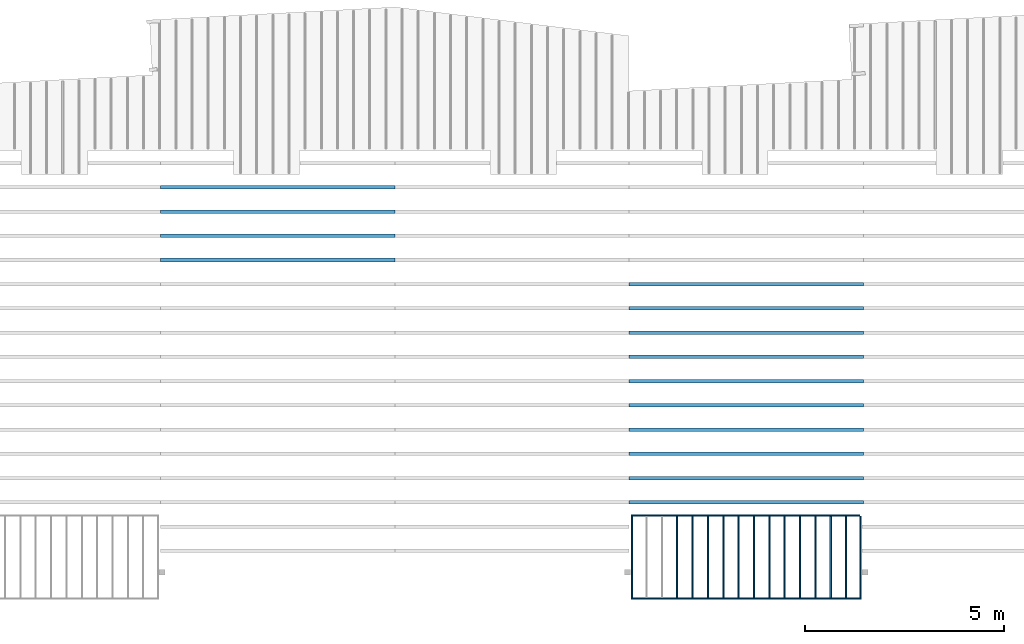
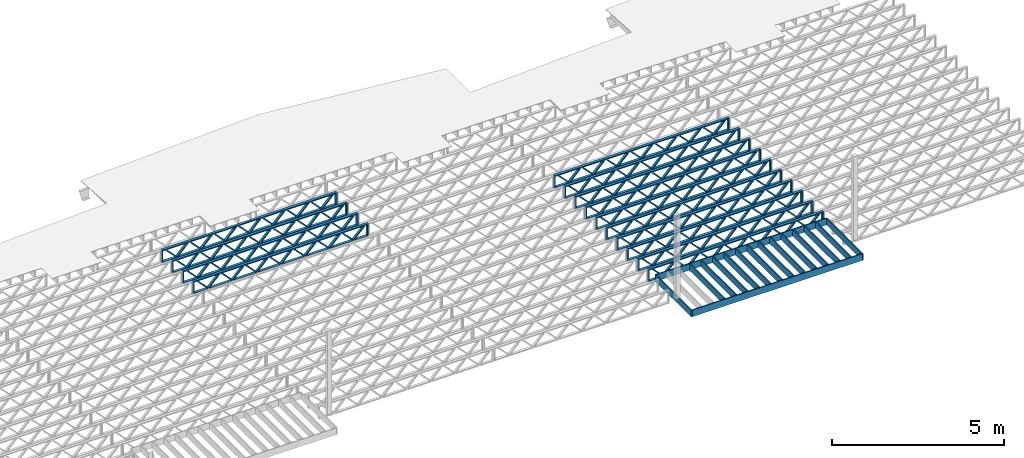
# One storey, part 7 of 13: 30 beams, 3 elements without a shape of their own.
"""IFC4 building model written with IfcOpenShell, lengths in feet."""

from ifc_helpers import new_model, entity, si_unit, converted_unit, derived_unit, direction, frame, frame_2d, origin, origin_2d_with_axis, place, context, subcontext, project, spatial, rectangle, extrude, source, transform, mapped, material, material_profile, profile_set, profile_usage, type_object, type_shapes, element, aggregate, save


model = new_model("IFC4")

# Units and contexts
model_context_1 = context("Model", 3, precision=0.0001, world=origin(), true_north=direction((6.12303176911189e-17, 1.0)))
model_context_2 = context("Model", 3, precision=0.0001, world=origin(), true_north=direction((6.12303176911189e-17, 1.0)))
body_context = subcontext(model_context_2, "Body", "Model", "MODEL_VIEW")
ifc_project = project(units=[converted_unit("LENGTHUNIT", "FOOT", entity("IfcRatioMeasure", 0.3048), si_unit("LENGTHUNIT", "METRE"), dimensions=[1, 0, 0, 0, 0, 0, 0]), converted_unit("AREAUNIT", "SQUARE FOOT", entity("IfcRatioMeasure", 0.09290304), si_unit("AREAUNIT", "SQUARE_METRE"), dimensions=[2, 0, 0, 0, 0, 0, 0]), converted_unit("VOLUMEUNIT", "CUBIC FOOT", entity("IfcRatioMeasure", 0.028316846592), si_unit("VOLUMEUNIT", "CUBIC_METRE"), dimensions=[3, 0, 0, 0, 0, 0, 0]), converted_unit("PLANEANGLEUNIT", "DEGREE", entity("IfcRatioMeasure", 0.0174532925199433), si_unit("PLANEANGLEUNIT", "RADIAN"), dimensions=[0, 0, 0, 0, 0, 0, 0]), si_unit("MASSUNIT", "GRAM", prefix="KILO"), derived_unit("MASSDENSITYUNIT", [(si_unit("MASSUNIT", "GRAM", prefix="KILO"), 1), (si_unit("LENGTHUNIT", "METRE"), -3)]), derived_unit("MOMENTOFINERTIAUNIT", [(si_unit("LENGTHUNIT", "METRE"), 4)]), si_unit("TIMEUNIT", "SECOND"), si_unit("FREQUENCYUNIT", "HERTZ"), si_unit("THERMODYNAMICTEMPERATUREUNIT", "DEGREE_CELSIUS"), derived_unit("THERMALTRANSMITTANCEUNIT", [(si_unit("MASSUNIT", "GRAM", prefix="KILO"), 1), (si_unit("THERMODYNAMICTEMPERATUREUNIT", "KELVIN"), -1), (si_unit("TIMEUNIT", "SECOND"), -3)]), derived_unit("VOLUMETRICFLOWRATEUNIT", [(si_unit("LENGTHUNIT", "METRE"), 3), (si_unit("TIMEUNIT", "SECOND"), -1)]), si_unit("ELECTRICCURRENTUNIT", "AMPERE"), si_unit("ELECTRICVOLTAGEUNIT", "VOLT"), si_unit("POWERUNIT", "WATT"), si_unit("FORCEUNIT", "NEWTON"), si_unit("ILLUMINANCEUNIT", "LUX"), si_unit("LUMINOUSFLUXUNIT", "LUMEN"), si_unit("LUMINOUSINTENSITYUNIT", "CANDELA"), derived_unit("USERDEFINED", [(si_unit("MASSUNIT", "GRAM", prefix="KILO"), -1), (si_unit("LENGTHUNIT", "METRE"), -2), (si_unit("TIMEUNIT", "SECOND"), 3), (si_unit("LUMINOUSFLUXUNIT", "LUMEN"), 1)]), derived_unit("LINEARVELOCITYUNIT", [(si_unit("LENGTHUNIT", "METRE"), 1), (si_unit("TIMEUNIT", "SECOND"), -1)]), si_unit("PRESSUREUNIT", "PASCAL"), derived_unit("USERDEFINED", [(si_unit("LENGTHUNIT", "METRE"), -2), (si_unit("MASSUNIT", "GRAM", prefix="KILO"), 1), (si_unit("TIMEUNIT", "SECOND"), -2)]), derived_unit("LINEARFORCEUNIT", [(si_unit("MASSUNIT", "GRAM", prefix="KILO"), 1), (si_unit("LENGTHUNIT", "METRE"), 1), (si_unit("TIMEUNIT", "SECOND"), -2), (si_unit("LENGTHUNIT", "METRE"), -1)]), derived_unit("PLANARFORCEUNIT", [(si_unit("MASSUNIT", "GRAM", prefix="KILO"), 1), (si_unit("LENGTHUNIT", "METRE"), 1), (si_unit("TIMEUNIT", "SECOND"), -2), (si_unit("LENGTHUNIT", "METRE"), -2)])], contexts=[model_context_1])

# Site, building, storey
site_placement = place(None, origin())
site = spatial("IfcSite", under=ifc_project, at=site_placement, CompositionType="ELEMENT")
building_placement = place(site_placement, origin())
building = spatial("IfcBuilding", under=site, at=building_placement, CompositionType="ELEMENT")
storey_placement = place(building_placement, frame((0.0, 0.0, 21.46875)))
storey = spatial("IfcBuildingStorey", under=building, at=storey_placement, Name="3RD FLOOR", CompositionType="ELEMENT", Elevation=21.46875)

# Assembly, beams
assembly_1_placement = place(storey_placement, origin())
assembly_1 = element("IfcElementAssembly", 1, at=assembly_1_placement, inside=storey, Name="Structural Beam System:Structural Framing System", ObjectType="Structural Beam System:Structural Framing System", AssemblyPlace="NOTDEFINED", PredefinedType="BEAM_GRID")
ifc_material_1 = material(Name="WOOD TRUSS", Category="Materials")
ifc_material_profile_1 = material_profile(ifc_material_1, rectangle(XDim=1.73473973950632, YDim=0.125, at=frame_2d((-1.11022302462516e-16, 8.32667268468867e-17), x_axis=(1.0, 0.0))))
ifc_material_profile_2 = material_profile(ifc_material_1, rectangle(XDim=1.73473973950633, YDim=0.125, at=frame_2d((-1.11022302462516e-16, 8.32667268468867e-17), x_axis=(1.0, 0.0))))
ifc_material_profile_3 = material_profile(ifc_material_1, rectangle(XDim=1.73473973950632, YDim=0.125, at=frame_2d((-5.55111512312578e-17, 1.38777878078145e-16), x_axis=(1.0, 0.0))))
ifc_material_profile_4 = material_profile(ifc_material_1, rectangle(XDim=1.73473973950633, YDim=0.125, at=frame_2d((-1.11022302462516e-16, 8.32667268468867e-17), x_axis=(1.0, 0.0))))
ifc_material_profile_5 = material_profile(ifc_material_1, rectangle(XDim=1.73473973950632, YDim=0.125, at=frame_2d((-1.11022302462516e-16, 8.32667268468867e-17), x_axis=(1.0, 0.0))))
ifc_material_profile_6 = material_profile(ifc_material_1, rectangle(XDim=1.73473973950633, YDim=0.125, at=frame_2d((-2.77555756156289e-16, 3.05311331771918e-16), x_axis=(1.0, 0.0))))
ifc_material_profile_7 = material_profile(ifc_material_1, rectangle(XDim=1.73473973950632, YDim=0.124999999999999, at=frame_2d((-3.88578058618805e-16, -2.4980018054066e-16), x_axis=(1.0, 0.0))))
ifc_material_profile_8 = material_profile(ifc_material_1, rectangle(XDim=1.73473973950633, YDim=0.125, at=frame_2d((2.77555756156289e-16, -3.05311331771918e-16), x_axis=(1.0, 0.0))))
ifc_material_profile_9 = material_profile(ifc_material_1, rectangle(XDim=1.73473973950632, YDim=0.124999999999999, at=frame_2d((-1.11022302462516e-16, 8.32667268468867e-17), x_axis=(1.0, 0.0))))
ifc_material_profile_10 = material_profile(ifc_material_1, rectangle(XDim=1.73473973950633, YDim=0.125, at=origin_2d_with_axis()))
ifc_material_profile_11 = material_profile(ifc_material_1, rectangle(XDim=0.124999999999982, YDim=0.291666666666668, at=origin_2d_with_axis()))
ifc_material_profile_12 = material_profile(ifc_material_1, rectangle(XDim=0.124999999999932, YDim=0.291666666666664, at=origin_2d_with_axis()))
ifc_material_profile_13 = material_profile(ifc_material_1, rectangle(XDim=1.25000000000002, YDim=0.29166666666667, at=origin_2d_with_axis()))
ifc_material_profile_14 = material_profile(ifc_material_1, rectangle(XDim=1.25000000000004, YDim=0.291666666666667, at=origin_2d_with_axis()))
ifc_profile_set_1 = profile_set([ifc_material_profile_1, ifc_material_profile_2, ifc_material_profile_3, ifc_material_profile_4, ifc_material_profile_5, ifc_material_profile_6, ifc_material_profile_7, ifc_material_profile_8, ifc_material_profile_9, ifc_material_profile_10, ifc_material_profile_11, ifc_material_profile_12, ifc_material_profile_13, ifc_material_profile_14])
ifc_profile_usage_1 = profile_usage(ifc_profile_set_1, cardinal=8)
beam_type_1 = type_object("IfcBeamType", PredefinedType="BEAM", material=ifc_profile_set_1)
shared_shape_1 = source(origin(), body_context, "Body", "SweptSolid", [
    extrude(rectangle(XDim=1.73473973950632, YDim=0.124999999999999, at=frame_2d((5.55111512312578e-16, 7.21644966006352e-16), x_axis=(1.0, 0.0))), frame((5.95847627016997, -0.145833333333334, 0.0), z_axis=(0.0, 1.0, 0.0), x_axis=(0.693383046997606, 0.0, 0.720569184836762)), (0.0, 0.0, 1.0), 0.291666666666667),
    extrude(rectangle(XDim=1.73473973950633, YDim=0.125, at=origin_2d_with_axis()), frame((4.7081903964967, -0.145833333333334, 0.0), z_axis=(0.0, 1.0, 0.0), x_axis=(0.69338304699761, 0.0, -0.720569184836758)), (0.0, 0.0, 1.0), 0.291666666666666),
    extrude(rectangle(XDim=1.73473973950632, YDim=0.125, at=frame_2d((2.22044604925031e-16, 3.88578058618805e-16), x_axis=(1.0, 0.0))), frame((3.29180960350347, -0.145833333333334, 0.0), z_axis=(0.0, 1.0, 0.0), x_axis=(0.693383046997606, 0.0, 0.720569184836762)), (0.0, 0.0, 1.0), 0.291666666666667),
    extrude(rectangle(XDim=1.73473973950633, YDim=0.125, at=frame_2d((1.11022302462516e-16, -8.32667268468867e-17), x_axis=(1.0, 0.0))), frame((2.0415237298302, -0.145833333333334, 0.0), z_axis=(0.0, 1.0, 0.0), x_axis=(0.69338304699761, 0.0, -0.720569184836758)), (0.0, 0.0, 1.0), 0.291666666666667),
    extrude(rectangle(XDim=1.73473973950632, YDim=0.125, at=frame_2d((-5.55111512312578e-17, 1.38777878078145e-16), x_axis=(1.0, 0.0))), frame((0.625142936836964, -0.145833333333334, 0.0), z_axis=(0.0, 1.0, 0.0), x_axis=(0.693383046997606, 0.0, 0.720569184836762)), (0.0, 0.0, 1.0), 0.291666666666667),
    extrude(rectangle(XDim=1.73473973950633, YDim=0.125, at=frame_2d((-1.11022302462516e-16, 8.32667268468867e-17), x_axis=(1.0, 0.0))), frame((-0.625142936836306, -0.145833333333334, 0.0), z_axis=(0.0, 1.0, 0.0), x_axis=(0.69338304699761, 0.0, -0.720569184836758)), (0.0, 0.0, 1.0), 0.291666666666667),
    extrude(rectangle(XDim=1.73473973950632, YDim=0.125, at=frame_2d((-1.11022302462516e-16, 8.32667268468867e-17), x_axis=(1.0, 0.0))), frame((-2.04152372982954, -0.145833333333334, 0.0), z_axis=(0.0, 1.0, 0.0), x_axis=(0.693383046997606, 0.0, 0.720569184836762)), (0.0, 0.0, 1.0), 0.291666666666667),
    extrude(rectangle(XDim=1.73473973950633, YDim=0.125, at=origin_2d_with_axis()), frame((-3.29180960350281, -0.145833333333334, 0.0), z_axis=(0.0, 1.0, 0.0), x_axis=(0.69338304699761, 0.0, -0.720569184836758)), (0.0, 0.0, 1.0), 0.291666666666667),
    extrude(rectangle(XDim=1.73473973950632, YDim=0.124999999999999, at=frame_2d((-1.11022302462516e-16, 8.32667268468867e-17), x_axis=(1.0, 0.0))), frame((-4.70819039649604, -0.145833333333334, 0.0), z_axis=(0.0, 1.0, 0.0), x_axis=(0.693383046997606, 0.0, 0.720569184836762)), (0.0, 0.0, 1.0), 0.291666666666667),
    extrude(rectangle(XDim=1.73473973950633, YDim=0.125, at=frame_2d((-5.55111512312578e-16, 6.38378239159465e-16), x_axis=(1.0, 0.0))), frame((-5.95847627016931, -0.145833333333334, 0.0), z_axis=(0.0, 1.0, 0.0), x_axis=(0.69338304699761, 0.0, -0.720569184836758)), (0.0, 0.0, 1.0), 0.291666666666666),
    extrude(rectangle(XDim=1.73473973950632, YDim=0.125, at=frame_2d((-7.21644966006352e-16, -5.82867087928207e-16), x_axis=(1.0, 0.0))), frame((8.62514293683647, -0.145833333333334, 0.0), z_axis=(0.0, 1.0, 0.0), x_axis=(0.693383046997607, 0.0, 0.720569184836761)), (0.0, 0.0, 1.0), 0.291666666666667),
    extrude(rectangle(XDim=1.73473973950633, YDim=0.125, at=origin_2d_with_axis()), frame((7.3748570631632, -0.145833333333334, 0.0), z_axis=(0.0, 1.0, 0.0), x_axis=(0.69338304699761, 0.0, -0.720569184836758)), (0.0, 0.0, 1.0), 0.291666666666666),
    extrude(rectangle(XDim=1.73473973950632, YDim=0.124999999999999, at=frame_2d((-1.11022302462516e-16, 8.32667268468867e-17), x_axis=(1.0, 0.0))), frame((-7.37485706316255, -0.145833333333334, 0.0), z_axis=(0.0, 1.0, 0.0), x_axis=(0.693383046997606, 0.0, 0.720569184836762)), (0.0, 0.0, 1.0), 0.291666666666667),
    extrude(rectangle(XDim=1.73473973950633, YDim=0.125, at=origin_2d_with_axis()), frame((-8.62514293683582, -0.145833333333334, 0.0), z_axis=(0.0, 1.0, 0.0), x_axis=(0.69338304699761, 0.0, -0.720569184836758)), (0.0, 0.0, 1.0), 0.291666666666666),
    extrude(rectangle(XDim=0.124999999999982, YDim=0.291666666666668, at=origin_2d_with_axis()), frame((-9.66666666666609, 0.0, 0.687500000000054), z_axis=(1.0, 0.0, 0.0), x_axis=(0.0, 0.0, -1.0)), (0.0, 0.0, 1.0), 19.3333333333322),
    extrude(rectangle(XDim=0.124999999999932, YDim=0.291666666666664, at=origin_2d_with_axis()), frame((-9.66666666666588, 0.0, -0.687499999999984), z_axis=(1.0, 0.0, 0.0), x_axis=(0.0, 0.0, -1.0)), (0.0, 0.0, 1.0), 19.333333333332),
    extrude(rectangle(XDim=1.25000000000002, YDim=0.29166666666667, at=origin_2d_with_axis()), frame((9.54166666666607, 0.0, 0.0), z_axis=(1.0, 0.0, 0.0), x_axis=(0.0, 0.0, -1.0)), (0.0, 0.0, 1.0), 0.12500000000002),
    extrude(rectangle(XDim=1.25000000000004, YDim=0.291666666666667, at=origin_2d_with_axis()), frame((-9.66666666666609, 0.0, 0.0), z_axis=(1.0, 0.0, 0.0), x_axis=(0.0, 0.0, -1.0)), (0.0, 0.0, 1.0), 0.125000000000023),
])
type_shapes(beam_type_1, [shared_shape_1])
beam_1_placement = place(assembly_1_placement, frame((-174.071493818896, 947.861934882651, -0.947916666666661), z_axis=(0.0, 0.0, 1.0), x_axis=(-1.0, 0.0, 0.0)))
beam_1 = element("IfcBeam", 2, at=beam_1_placement, type_object=beam_type_1, material=ifc_profile_usage_1, PredefinedType="BEAM", context=body_context, shape_type="MappedRepresentation", body=[
    mapped(shared_shape_1, transform((0.0, 0.0, 0.0), scale=1.0)),
])
ifc_profile_usage_2 = profile_usage(ifc_profile_set_1, cardinal=8)
beam_2_placement = place(assembly_1_placement, frame((-174.071493818896, 945.861934882651, -0.947916666666661), z_axis=(0.0, 0.0, 1.0), x_axis=(-1.0, 0.0, 0.0)))
beam_2 = element("IfcBeam", 3, at=beam_2_placement, type_object=beam_type_1, material=ifc_profile_usage_2, PredefinedType="BEAM", context=body_context, shape_type="MappedRepresentation", body=[
    mapped(shared_shape_1, transform((0.0, 0.0, 0.0), scale=1.0)),
])
ifc_profile_usage_3 = profile_usage(ifc_profile_set_1, cardinal=8)
beam_3_placement = place(assembly_1_placement, frame((-174.071493818896, 943.861934882651, -0.947916666666661), z_axis=(0.0, 0.0, 1.0), x_axis=(-1.0, 0.0, 0.0)))
beam_3 = element("IfcBeam", 4, at=beam_3_placement, type_object=beam_type_1, material=ifc_profile_usage_3, PredefinedType="BEAM", context=body_context, shape_type="MappedRepresentation", body=[
    mapped(shared_shape_1, transform((0.0, 0.0, 0.0), scale=1.0)),
])
ifc_profile_usage_4 = profile_usage(ifc_profile_set_1, cardinal=8)
beam_4_placement = place(assembly_1_placement, frame((-174.071493818896, 941.861934882651, -0.947916666666661), z_axis=(0.0, 0.0, 1.0), x_axis=(-1.0, 0.0, 0.0)))
beam_4 = element("IfcBeam", 5, at=beam_4_placement, type_object=beam_type_1, material=ifc_profile_usage_4, PredefinedType="BEAM", context=body_context, shape_type="MappedRepresentation", body=[
    mapped(shared_shape_1, transform((0.0, 0.0, 0.0), scale=1.0)),
])
ifc_profile_usage_5 = profile_usage(ifc_profile_set_1, cardinal=8)
beam_5_placement = place(assembly_1_placement, frame((-174.071493818896, 939.861934882651, -0.947916666666661), z_axis=(0.0, 0.0, 1.0), x_axis=(-1.0, 0.0, 0.0)))
beam_5 = element("IfcBeam", 6, at=beam_5_placement, type_object=beam_type_1, material=ifc_profile_usage_5, PredefinedType="BEAM", context=body_context, shape_type="MappedRepresentation", body=[
    mapped(shared_shape_1, transform((0.0, 0.0, 0.0), scale=1.0)),
])
ifc_profile_usage_6 = profile_usage(ifc_profile_set_1, cardinal=8)
beam_6_placement = place(assembly_1_placement, frame((-174.071493818896, 937.861934882651, -0.947916666666661), z_axis=(0.0, 0.0, 1.0), x_axis=(-1.0, 0.0, 0.0)))
beam_6 = element("IfcBeam", 7, at=beam_6_placement, type_object=beam_type_1, material=ifc_profile_usage_6, PredefinedType="BEAM", context=body_context, shape_type="MappedRepresentation", body=[
    mapped(shared_shape_1, transform((0.0, 0.0, 0.0), scale=1.0)),
])
ifc_profile_usage_7 = profile_usage(ifc_profile_set_1, cardinal=8)
beam_7_placement = place(assembly_1_placement, frame((-174.071493818896, 935.861934882651, -0.947916666666661), z_axis=(0.0, 0.0, 1.0), x_axis=(-1.0, 0.0, 0.0)))
beam_7 = element("IfcBeam", 8, at=beam_7_placement, type_object=beam_type_1, material=ifc_profile_usage_7, PredefinedType="BEAM", context=body_context, shape_type="MappedRepresentation", body=[
    mapped(shared_shape_1, transform((0.0, 0.0, 0.0), scale=1.0)),
])
ifc_profile_usage_8 = profile_usage(ifc_profile_set_1, cardinal=8)
beam_8_placement = place(assembly_1_placement, frame((-174.071493818896, 933.861934882651, -0.947916666666661), z_axis=(0.0, 0.0, 1.0), x_axis=(-1.0, 0.0, 0.0)))
beam_8 = element("IfcBeam", 9, at=beam_8_placement, type_object=beam_type_1, material=ifc_profile_usage_8, PredefinedType="BEAM", context=body_context, shape_type="MappedRepresentation", body=[
    mapped(shared_shape_1, transform((0.0, 0.0, 0.0), scale=1.0)),
])
ifc_profile_usage_9 = profile_usage(ifc_profile_set_1, cardinal=8)
beam_9_placement = place(assembly_1_placement, frame((-174.071493818896, 931.861934882651, -0.947916666666661), z_axis=(0.0, 0.0, 1.0), x_axis=(-1.0, 0.0, 0.0)))
beam_9 = element("IfcBeam", 10, at=beam_9_placement, type_object=beam_type_1, material=ifc_profile_usage_9, PredefinedType="BEAM", context=body_context, shape_type="MappedRepresentation", body=[
    mapped(shared_shape_1, transform((0.0, 0.0, 0.0), scale=1.0)),
])
ifc_profile_usage_10 = profile_usage(ifc_profile_set_1, cardinal=8)
beam_10_placement = place(assembly_1_placement, frame((-174.071493818896, 929.861934882651, -0.947916666666661), z_axis=(0.0, 0.0, 1.0), x_axis=(-1.0, 0.0, 0.0)))
beam_10 = element("IfcBeam", 11, at=beam_10_placement, type_object=beam_type_1, material=ifc_profile_usage_10, PredefinedType="BEAM", context=body_context, shape_type="MappedRepresentation", body=[
    mapped(shared_shape_1, transform((0.0, 0.0, 0.0), scale=1.0)),
])
aggregate(assembly_1, [beam_1, beam_2, beam_3, beam_4, beam_5, beam_6, beam_7, beam_8, beam_9, beam_10])

assembly_2_placement = place(storey_placement, origin())
assembly_2 = element("IfcElementAssembly", 12, at=assembly_2_placement, inside=storey, Name="Structural Beam System:Structural Framing System", ObjectType="Structural Beam System:Structural Framing System", AssemblyPlace="NOTDEFINED", PredefinedType="BEAM_GRID")
ifc_profile_usage_11 = profile_usage(ifc_profile_set_1, cardinal=8)
beam_11_placement = place(assembly_2_placement, frame((-212.738160485495, 955.861934882651, -0.947916666666881), z_axis=(0.0, 0.0, 1.0), x_axis=(-1.0, 0.0, 0.0)))
beam_11 = element("IfcBeam", 13, at=beam_11_placement, type_object=beam_type_1, material=ifc_profile_usage_11, PredefinedType="BEAM", context=body_context, shape_type="MappedRepresentation", body=[
    mapped(shared_shape_1, transform((0.0, 0.0, 0.0), scale=1.0)),
])
ifc_profile_usage_12 = profile_usage(ifc_profile_set_1, cardinal=8)
beam_12_placement = place(assembly_2_placement, frame((-212.738160485495, 953.861934882651, -0.947916666666881), z_axis=(0.0, 0.0, 1.0), x_axis=(-1.0, 0.0, 0.0)))
beam_12 = element("IfcBeam", 14, at=beam_12_placement, type_object=beam_type_1, material=ifc_profile_usage_12, PredefinedType="BEAM", context=body_context, shape_type="MappedRepresentation", body=[
    mapped(shared_shape_1, transform((0.0, 0.0, 0.0), scale=1.0)),
])
ifc_profile_usage_13 = profile_usage(ifc_profile_set_1, cardinal=8)
beam_13_placement = place(assembly_2_placement, frame((-212.738160485495, 951.861934882651, -0.947916666666881), z_axis=(0.0, 0.0, 1.0), x_axis=(-1.0, 0.0, 0.0)))
beam_13 = element("IfcBeam", 15, at=beam_13_placement, type_object=beam_type_1, material=ifc_profile_usage_13, PredefinedType="BEAM", context=body_context, shape_type="MappedRepresentation", body=[
    mapped(shared_shape_1, transform((0.0, 0.0, 0.0), scale=1.0)),
])
ifc_profile_usage_14 = profile_usage(ifc_profile_set_1, cardinal=8)
beam_14_placement = place(assembly_2_placement, frame((-212.738160485495, 949.861934882651, -0.947916666666881), z_axis=(0.0, 0.0, 1.0), x_axis=(-1.0, 0.0, 0.0)))
beam_14 = element("IfcBeam", 16, at=beam_14_placement, type_object=beam_type_1, material=ifc_profile_usage_14, PredefinedType="BEAM", context=body_context, shape_type="MappedRepresentation", body=[
    mapped(shared_shape_1, transform((0.0, 0.0, 0.0), scale=1.0)),
])
aggregate(assembly_2, [beam_11, beam_12, beam_13, beam_14])

assembly_3_placement = place(storey_placement, origin())
assembly_3 = element("IfcElementAssembly", 17, at=assembly_3_placement, inside=storey, Name="Structural Beam System:Structural Framing System", ObjectType="Structural Beam System:Structural Framing System", AssemblyPlace="NOTDEFINED", PredefinedType="BEAM_GRID")
ifc_material_2 = material(Category="Materials")
ifc_material_profile_15 = material_profile(ifc_material_2, rectangle(XDim=0.770833333333333, YDim=0.124999999999994, at=frame_2d((-5.55111512312578e-17, 0.0), x_axis=(1.0, 0.0))))
ifc_profile_set_2 = profile_set([ifc_material_profile_15])
ifc_profile_usage_15 = profile_usage(ifc_profile_set_2, cardinal=8)
beam_type_2 = type_object("IfcBeamType", PredefinedType="BEAM", material=ifc_profile_set_2)
shared_shape_2 = source(origin(), body_context, "Body", "SweptSolid", [
    extrude(rectangle(XDim=0.770833333333333, YDim=0.124999999999994, at=frame_2d((-5.55111512312578e-17, 0.0), x_axis=(1.0, 0.0))), frame((-3.35416666666737, 0.0, 0.0), z_axis=(1.0, 0.0, 0.0), x_axis=(0.0, 0.0, -1.0)), (0.0, 0.0, 1.0), 6.70833333333462),
])
type_shapes(beam_type_2, [shared_shape_2])
beam_15_placement = place(assembly_3_placement, frame((-165.835122291113, 925.341101549316, -0.645833333333474), z_axis=(0.0, 0.0, 1.0), x_axis=(0.0, 1.0, 0.0)))
beam_15 = element("IfcBeam", 18, at=beam_15_placement, type_object=beam_type_2, material=ifc_profile_usage_15, PredefinedType="BEAM", context=body_context, shape_type="MappedRepresentation", body=[
    mapped(shared_shape_2, transform((0.0, 0.0, 0.0), scale=1.0)),
])
ifc_profile_usage_16 = profile_usage(ifc_profile_set_2, cardinal=8)
beam_16_placement = place(assembly_3_placement, frame((-167.102005971671, 925.341101549316, -0.645833333333474), z_axis=(0.0, 0.0, 1.0), x_axis=(0.0, 1.0, 0.0)))
beam_16 = element("IfcBeam", 19, at=beam_16_placement, type_object=beam_type_2, material=ifc_profile_usage_16, PredefinedType="BEAM", context=body_context, shape_type="MappedRepresentation", body=[
    mapped(shared_shape_2, transform((0.0, 0.0, 0.0), scale=1.0)),
])
ifc_profile_usage_17 = profile_usage(ifc_profile_set_2, cardinal=8)
beam_17_placement = place(assembly_3_placement, frame((-168.368889652229, 925.341101549316, -0.645833333333474), z_axis=(0.0, 0.0, 1.0), x_axis=(0.0, 1.0, 0.0)))
beam_17 = element("IfcBeam", 20, at=beam_17_placement, type_object=beam_type_2, material=ifc_profile_usage_17, PredefinedType="BEAM", context=body_context, shape_type="MappedRepresentation", body=[
    mapped(shared_shape_2, transform((0.0, 0.0, 0.0), scale=1.0)),
])
ifc_profile_usage_18 = profile_usage(ifc_profile_set_2, cardinal=8)
beam_18_placement = place(assembly_3_placement, frame((-169.635773332788, 925.341101549317, -0.645833333333474), z_axis=(0.0, 0.0, 1.0), x_axis=(0.0, 1.0, 0.0)))
beam_18 = element("IfcBeam", 21, at=beam_18_placement, type_object=beam_type_2, material=ifc_profile_usage_18, PredefinedType="BEAM", context=body_context, shape_type="MappedRepresentation", body=[
    mapped(shared_shape_2, transform((0.0, 0.0, 0.0), scale=1.0)),
])
ifc_profile_usage_19 = profile_usage(ifc_profile_set_2, cardinal=8)
beam_19_placement = place(assembly_3_placement, frame((-170.902657013346, 925.341101549317, -0.645833333333474), z_axis=(0.0, 0.0, 1.0), x_axis=(0.0, 1.0, 0.0)))
beam_19 = element("IfcBeam", 22, at=beam_19_placement, type_object=beam_type_2, material=ifc_profile_usage_19, PredefinedType="BEAM", context=body_context, shape_type="MappedRepresentation", body=[
    mapped(shared_shape_2, transform((0.0, 0.0, 0.0), scale=1.0)),
])
ifc_profile_usage_20 = profile_usage(ifc_profile_set_2, cardinal=8)
beam_20_placement = place(assembly_3_placement, frame((-172.169540693904, 925.341101549317, -0.645833333333474), z_axis=(0.0, 0.0, 1.0), x_axis=(0.0, 1.0, 0.0)))
beam_20 = element("IfcBeam", 23, at=beam_20_placement, type_object=beam_type_2, material=ifc_profile_usage_20, PredefinedType="BEAM", context=body_context, shape_type="MappedRepresentation", body=[
    mapped(shared_shape_2, transform((0.0, 0.0, 0.0), scale=1.0)),
])
ifc_profile_usage_21 = profile_usage(ifc_profile_set_2, cardinal=8)
beam_21_placement = place(assembly_3_placement, frame((-173.436424374463, 925.341101549317, -0.645833333333474), z_axis=(0.0, 0.0, 1.0), x_axis=(0.0, 1.0, 0.0)))
beam_21 = element("IfcBeam", 24, at=beam_21_placement, type_object=beam_type_2, material=ifc_profile_usage_21, PredefinedType="BEAM", context=body_context, shape_type="MappedRepresentation", body=[
    mapped(shared_shape_2, transform((0.0, 0.0, 0.0), scale=1.0)),
])
ifc_profile_usage_22 = profile_usage(ifc_profile_set_2, cardinal=8)
beam_22_placement = place(assembly_3_placement, frame((-174.703308055021, 925.341101549318, -0.645833333333435), z_axis=(0.0, 0.0, 1.0), x_axis=(0.0, 1.0, 0.0)))
beam_22 = element("IfcBeam", 25, at=beam_22_placement, type_object=beam_type_2, material=ifc_profile_usage_22, PredefinedType="BEAM", context=body_context, shape_type="MappedRepresentation", body=[
    mapped(shared_shape_2, transform((0.0, 0.0, 0.0), scale=1.0)),
])
ifc_profile_usage_23 = profile_usage(ifc_profile_set_2, cardinal=8)
beam_23_placement = place(assembly_3_placement, frame((-175.970191735579, 925.341101549318, -0.645833333333474), z_axis=(0.0, 0.0, 1.0), x_axis=(0.0, 1.0, 0.0)))
beam_23 = element("IfcBeam", 26, at=beam_23_placement, type_object=beam_type_2, material=ifc_profile_usage_23, PredefinedType="BEAM", context=body_context, shape_type="MappedRepresentation", body=[
    mapped(shared_shape_2, transform((0.0, 0.0, 0.0), scale=1.0)),
])
ifc_profile_usage_24 = profile_usage(ifc_profile_set_2, cardinal=8)
beam_24_placement = place(assembly_3_placement, frame((-177.237075416138, 925.341101549318, -0.645833333333474), z_axis=(0.0, 0.0, 1.0), x_axis=(0.0, 1.0, 0.0)))
beam_24 = element("IfcBeam", 27, at=beam_24_placement, type_object=beam_type_2, material=ifc_profile_usage_24, PredefinedType="BEAM", context=body_context, shape_type="MappedRepresentation", body=[
    mapped(shared_shape_2, transform((0.0, 0.0, 0.0), scale=1.0)),
])
ifc_profile_usage_25 = profile_usage(ifc_profile_set_2, cardinal=8)
beam_25_placement = place(assembly_3_placement, frame((-178.503959096696, 925.341101549318, -0.645833333333474), z_axis=(0.0, 0.0, 1.0), x_axis=(0.0, 1.0, 0.0)))
beam_25 = element("IfcBeam", 28, at=beam_25_placement, type_object=beam_type_2, material=ifc_profile_usage_25, PredefinedType="BEAM", context=body_context, shape_type="MappedRepresentation", body=[
    mapped(shared_shape_2, transform((0.0, 0.0, 0.0), scale=1.0)),
])
ifc_profile_usage_26 = profile_usage(ifc_profile_set_2, cardinal=8)
beam_26_placement = place(assembly_3_placement, frame((-179.770842777255, 925.341101549318, -0.645833333333474), z_axis=(0.0, 0.0, 1.0), x_axis=(0.0, 1.0, 0.0)))
beam_26 = element("IfcBeam", 29, at=beam_26_placement, type_object=beam_type_2, material=ifc_profile_usage_26, PredefinedType="BEAM", context=body_context, shape_type="MappedRepresentation", body=[
    mapped(shared_shape_2, transform((0.0, 0.0, 0.0), scale=1.0)),
])
aggregate(assembly_3, [beam_15, beam_16, beam_17, beam_18, beam_19, beam_20, beam_21, beam_22, beam_23, beam_24, beam_25, beam_26])

# Beams
ifc_material_3 = material(Name="BRAKE METAL FLASHING AT PERIMETER 2X LEDGER", Category="Materials")
ifc_material_profile_16 = material_profile(ifc_material_3, rectangle(XDim=0.770833333333333, YDim=0.124999999999994, at=frame_2d((-1.11022302462516e-16, 0.0), x_axis=(1.0, 0.0))), Name="BRAKE METAL FLASHING AT PERIMETER 2X LEDGER")
ifc_profile_set_3 = profile_set([ifc_material_profile_16], Name="BRAKE METAL FLASHING AT PERIMETER 2X LEDGER")
ifc_profile_usage_27 = profile_usage(ifc_profile_set_3, cardinal=8)
beam_type_3 = type_object("IfcBeamType", PredefinedType="BEAM", material=ifc_profile_set_3)
shared_shape_3 = source(origin(), body_context, "Body", "SweptSolid", [
    extrude(rectangle(XDim=0.770833333333333, YDim=0.124999999999994, at=frame_2d((-1.11022302462516e-16, 0.0), x_axis=(1.0, 0.0))), frame((-9.37499887751909, 0.0, 0.0), z_axis=(1.0, 0.0, 0.0), x_axis=(0.0, 0.0, -1.0)), (0.0, 0.0, 1.0), 18.7499977550382),
])
type_shapes(beam_type_3, [shared_shape_3])
beam_27_placement = place(storey_placement, frame((-174.071491964864, 921.92443488265, -0.645833333333496)))
element("IfcBeam", 30, at=beam_27_placement, inside=storey, type_object=beam_type_3, material=ifc_profile_usage_27, PredefinedType="BEAM", context=body_context, shape_type="MappedRepresentation", body=[
    mapped(shared_shape_3, transform((0.0, 0.0, 0.0), scale=1.0)),
])
ifc_profile_usage_28 = profile_usage(ifc_profile_set_2, cardinal=8)
beam_type_4 = type_object("IfcBeamType", PredefinedType="BEAM", material=ifc_profile_set_2)
shared_shape_4 = source(origin(), body_context, "Body", "SweptSolid", [
    extrude(rectangle(XDim=0.770833333333333, YDim=0.124999999999994, at=frame_2d((-1.11022302462516e-16, 0.0), x_axis=(1.0, 0.0))), frame((-9.49999887751909, 0.0, 0.0), z_axis=(1.0, 0.0, 0.0), x_axis=(0.0, 0.0, -1.0)), (0.0, 0.0, 1.0), 18.8749977550382),
])
type_shapes(beam_type_4, [shared_shape_4])
beam_28_placement = place(storey_placement, frame((-174.071491964864, 928.757768215985, -0.645833333333506)))
element("IfcBeam", 31, at=beam_28_placement, inside=storey, type_object=beam_type_4, material=ifc_profile_usage_28, PredefinedType="BEAM", context=body_context, shape_type="MappedRepresentation", body=[
    mapped(shared_shape_4, transform((0.0, 0.0, 0.0), scale=1.0)),
])
ifc_profile_usage_29 = profile_usage(ifc_profile_set_2, cardinal=8)
beam_type_5 = type_object("IfcBeamType", PredefinedType="BEAM", material=ifc_profile_set_2)
shared_shape_5 = source(origin(), body_context, "Body", "SweptSolid", [
    extrude(rectangle(XDim=0.770833333333333, YDim=0.124999999999994, at=frame_2d((-5.55111512312578e-17, 0.0), x_axis=(1.0, 0.0))), frame((-3.47916666666737, 0.0, 0.0), z_axis=(1.0, 0.0, 0.0), x_axis=(0.0, 0.0, -1.0)), (0.0, 0.0, 1.0), 6.83333333333485),
])
type_shapes(beam_type_5, [shared_shape_5])
beam_29_placement = place(storey_placement, frame((-164.633993087345, 925.341101549316, -0.645833333332799), z_axis=(0.0, 0.0, 1.0), x_axis=(0.0, 1.0, 0.0)))
element("IfcBeam", 32, at=beam_29_placement, inside=storey, type_object=beam_type_5, material=ifc_profile_usage_29, PredefinedType="BEAM", context=body_context, shape_type="MappedRepresentation", body=[
    mapped(shared_shape_5, transform((0.0, 0.0, 0.0), scale=1.0)),
])
ifc_profile_usage_30 = profile_usage(ifc_profile_set_2, cardinal=8)
beam_30_placement = place(storey_placement, frame((-183.508990842383, 925.341101549319, -0.645833333333513), z_axis=(0.0, 0.0, 1.0), x_axis=(0.0, 1.0, 0.0)))
element("IfcBeam", 33, at=beam_30_placement, inside=storey, type_object=beam_type_5, material=ifc_profile_usage_30, PredefinedType="BEAM", context=body_context, shape_type="MappedRepresentation", body=[
    mapped(shared_shape_5, transform((0.0, 0.0, 0.0), scale=1.0)),
])

save(model, "model.ifc")
